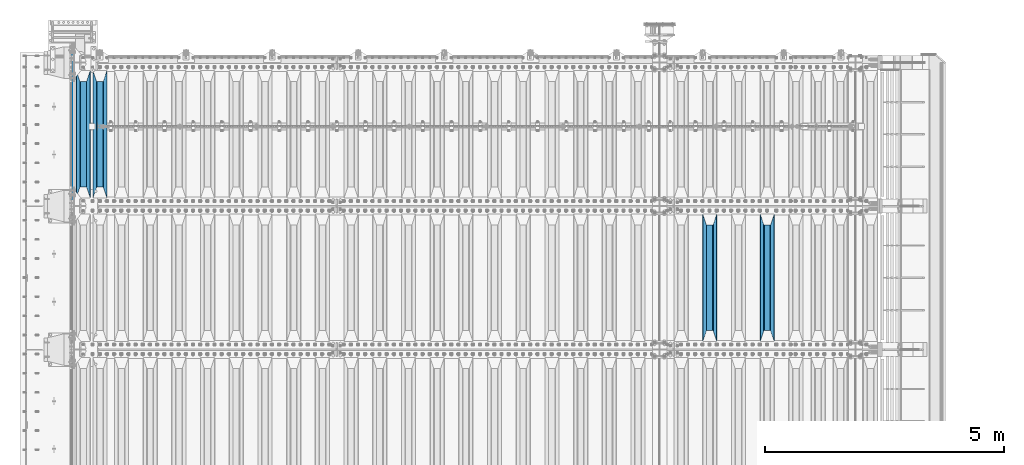
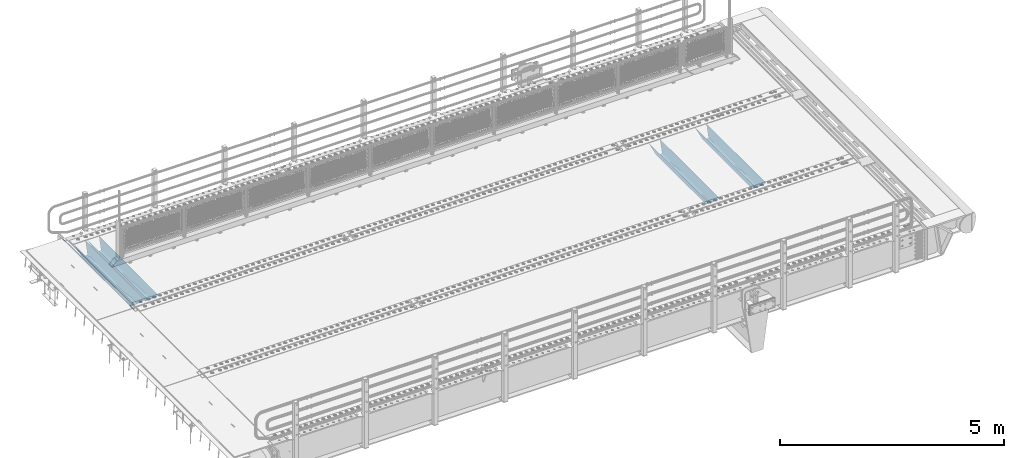
# One storey, part 119 of 247: 5 beams.
"""IFC2X3 building model written with IfcOpenShell, lengths in millimetres."""

from ifc_helpers import new_model, si_unit, frame, origin_with_axes, place, context, subcontext, project, spatial, faceted_brep, material, type_object, element, save


model = new_model("IFC2X3")

# Units and contexts
model_context = context("Model", 3, precision=1e-05, world=origin_with_axes())
body_context = subcontext(model_context, "Body", "Model", "MODEL_VIEW")
ifc_project = project(units=[si_unit("LENGTHUNIT", "METRE", prefix="MILLI"), si_unit("AREAUNIT", "SQUARE_METRE"), si_unit("VOLUMEUNIT", "CUBIC_METRE"), si_unit("MASSUNIT", "GRAM", prefix="KILO"), si_unit("TIMEUNIT", "SECOND"), si_unit("PLANEANGLEUNIT", "RADIAN"), si_unit("SOLIDANGLEUNIT", "STERADIAN"), si_unit("THERMODYNAMICTEMPERATUREUNIT", "DEGREE_CELSIUS"), si_unit("LUMINOUSINTENSITYUNIT", "LUMEN")], contexts=[model_context])

# Site, building, storey
site_placement = place(None, origin_with_axes())
site = spatial("IfcSite", under=ifc_project, at=site_placement, CompositionType="ELEMENT")
building_placement = place(site_placement, origin_with_axes())
building = spatial("IfcBuilding", under=site, at=building_placement, Name="Standard", CompositionType="ELEMENT")
storey_placement = place(building_placement, origin_with_axes())
storey = spatial("IfcBuildingStorey", under=building, at=storey_placement, Name="Undefined", CompositionType="ELEMENT", Elevation=0.0)

# Beams
ifc_material = material(Name="STEEL/S355N")
beam_type_1 = type_object("IfcBeamType", Name="D20", PredefinedType="NOTDEFINED")
beam_1_placement = place(storey_placement, frame((-35.0, 6004.99999999998, -25.9999999971316), z_axis=(0.0, 0.0, 1.0), x_axis=(0.0, 1.0, 0.0)))
element("IfcBeam", 1, at=beam_1_placement, inside=storey, type_object=beam_type_1, material=ifc_material, ObjectType="D20", context=body_context, shape_type="Brep", body=[
    faceted_brep([(-5.6843418860808e-14, -9.99999999999989, 3.5527136788005e-15), (0.0, -7.07106781186531, -7.07106781186547), (3144.99999999998, -7.07106781186548, -7.07106781186548), (3144.99999999998, -10.0, 0.0), (-5.6843418860808e-14, 0.0, -10.0), (3144.99999999998, 0.0, -10.0), (0.0, 7.07106781186565, -7.07106781186547), (3144.99999999998, 7.07106781186548, -7.07106781186547), (-5.6843418860808e-14, 10.0000000000001, 3.5527136788005e-15), (3144.99999999998, 10.0, 0.0), (-5.6843418860808e-14, 7.07106781186553, 7.07106781186548), (3144.99999999998, 7.07106781186548, 7.07106781186548), (0.0, 0.0, 10.0), (3144.99999999998, 0.0, 10.0), (-5.6843418860808e-14, -7.07106781186542, 7.07106781186548), (3144.99999999998, -7.07106781186548, 7.07106781186548)], [[[0, 1, 2, 3]], [[1, 4, 5, 2]], [[4, 6, 7, 5]], [[6, 8, 9, 7]], [[8, 10, 11, 9]], [[10, 12, 13, 11]], [[12, 14, 15, 13]], [[14, 0, 3, 15]], [[5, 7, 9, 11, 13, 15, 3, 2]], [[14, 12, 10, 8, 6, 4, 1, 0]]]),
])
beam_type_2 = type_object("IfcBeamType", PredefinedType="NOTDEFINED")
beam_2_placement = place(storey_placement, frame((14500.0, 3175.0, -115.0), z_axis=(0.0, 0.0, 1.0), x_axis=(0.0, 1.0, 0.0)))
element("IfcBeam", 2, at=beam_2_placement, inside=storey, type_object=beam_type_2, material=ifc_material, context=body_context, shape_type="Brep", body=[
    faceted_brep([(0.0, 150.0, 115.0), (0.0, 143.689999999999, 115.0), (2650.00000000297, 143.689999999999, 115.0), (2650.00000000297, 150.0, 115.0), (2650.00000000297, 142.059565218402, 110.0000000031), (2650.00000000297, 148.369565218403, 110.0000000031), (2441.90079219208, -80.1103600731112, -98.0992078077845), (2437.7588105432, -77.5672621345584, -102.241189456673), (2434.06523489746, -74.4080125315522, -105.934765102404), (2430.91086095089, -70.710272125576, -109.089139048974), (2428.37322971128, -66.5649389910068, -111.626770288588), (2426.51472138054, -62.0739139532889, -113.485278619323), (2425.38102192091, -57.3475956567672, -114.618978078955), (2424.99999999987, -52.5021667386536, -115.0), (2424.99999999987, 52.5021667386536, -115.0), (2425.38102192091, 57.3475956567672, -114.618978078955), (2426.51472138054, 62.0739139532889, -113.485278619323), (2428.37322971128, 66.5649389910068, -111.626770288588), (2430.91086095089, 70.710272125576, -109.089139048974), (2434.06523489746, 74.4080125315522, -105.934765102404), (2437.7588105432, 77.5672621345584, -102.241189456673), (2441.90079219208, 80.1103600731112, -98.0992078077846), (2446.38936140511, 81.9747917625791, -93.6106385947584), (2448.24948500409, 76.2713538057251, -91.7505149957729), (2444.62967112262, 74.76777986261, -95.3703288772456), (2441.28936334126, 72.7168944282894, -98.710636658607), (2438.31067330438, 70.1691124903846, -101.689326695487), (2435.76682334747, 67.1870637758839, -104.233176652398), (2433.72034654133, 63.8440531834895, -106.279653458539), (2432.22154950041, 60.222258798236, -107.778450499454), (2431.30727574265, 56.4107117849089, -108.692724257221), (2430.99999999987, 52.5031078186876, -109.0), (2430.99999999987, -52.5031078186876, -109.0), (2431.30727574265, -56.4107117849089, -108.692724257221), (2432.22154950041, -60.222258798236, -107.778450499454), (2433.72034654133, -63.8440531834895, -106.279653458539), (2435.76682334747, -67.1870637758839, -104.233176652398), (2438.31067330438, -70.1691124903846, -101.689326695487), (2441.28936334126, -72.7168944282894, -98.7106366586071), (2444.62967112262, -74.76777986261, -95.3703288772457), (2448.24948500409, -76.2713538057251, -91.7505149957729), (2650.00000000297, -142.059565218402, 110.0000000031), (2650.00000000297, -148.369565218403, 110.0000000031), (2446.38936140511, -81.9747917625791, -93.6106385947584), (2650.00000000297, -143.689999999999, 115.0), (2650.00000000297, -150.0, 115.0), (0.0, -143.689999999999, 115.0), (0.0, -150.0, 115.0), (0.0, -148.369565218261, 110.000000002663), (203.610638597422, -81.9747917625791, -93.6106385947584), (208.099207810448, -80.1103600731112, -98.0992078077845), (212.241189459336, -77.5672621345584, -102.241189456673), (215.934765105068, -74.4080125315522, -105.934765102404), (219.089139051637, -70.710272125576, -109.089139048974), (221.626770291251, -66.5649389910068, -111.626770288588), (223.485278621985, -62.0739139532889, -113.485278619323), (224.618978081617, -57.3475956567672, -114.618978078955), (225.000000002663, -52.5021667386536, -115.0), (225.000000002663, 52.5021667386536, -115.0), (224.618978081617, 57.3475956567672, -114.618978078955), (223.485278621985, 62.0739139532889, -113.485278619323), (221.626770291251, 66.5649389910068, -111.626770288588), (219.089139051637, 70.710272125576, -109.089139048974), (215.934765105068, 74.4080125315522, -105.934765102404), (212.241189459336, 77.5672621345584, -102.241189456673), (208.099207810448, 80.1103600731112, -98.0992078077846), (203.610638597422, 81.9747917625791, -93.6106385947584), (0.0, 148.369565218261, 110.000000002663), (0.0, 142.05956521826, 110.000000002663), (201.750514998436, 76.2713538057251, -91.7505149957729), (205.370328879908, 74.76777986261, -95.3703288772456), (208.710636661271, 72.7168944282894, -98.710636658607), (211.68932669815, 70.1691124903846, -101.689326695487), (214.233176655061, 67.1870637758839, -104.233176652398), (216.279653461202, 63.8440531834895, -106.279653458539), (217.778450502117, 60.222258798236, -107.778450499454), (218.692724259885, 56.4107117849089, -108.692724257221), (219.000000002663, 52.5031078186876, -109.0), (219.000000002663, -52.5031078186876, -109.0), (218.692724259885, -56.4107117849089, -108.692724257221), (217.778450502117, -60.222258798236, -107.778450499454), (216.279653461202, -63.8440531834895, -106.279653458539), (214.233176655061, -67.1870637758839, -104.233176652398), (211.68932669815, -70.1691124903846, -101.689326695487), (208.710636661271, -72.7168944282894, -98.7106366586071), (205.370328879908, -74.76777986261, -95.3703288772457), (201.750514998436, -76.2713538057251, -91.7505149957729), (0.0, -142.05956521826, 110.000000002663)], [[[0, 1, 2, 3]], [[3, 2, 4, 5]], [[6, 7, 8, 9, 10, 11, 12, 13, 14, 15, 16, 17, 18, 19, 20, 21, 22, 5, 4, 23, 24, 25, 26, 27, 28, 29, 30, 31, 32, 33, 34, 35, 36, 37, 38, 39, 40, 41, 42, 43]], [[44, 45, 42, 41]], [[46, 47, 45, 44]], [[43, 42, 45, 47, 48, 49]], [[6, 43, 49, 50]], [[7, 6, 50, 51]], [[8, 7, 51, 52]], [[9, 8, 52, 53]], [[10, 9, 53, 54]], [[11, 10, 54, 55]], [[12, 11, 55, 56]], [[13, 12, 56, 57]], [[14, 13, 57, 58]], [[15, 14, 58, 59]], [[16, 15, 59, 60]], [[17, 16, 60, 61]], [[18, 17, 61, 62]], [[19, 18, 62, 63]], [[20, 19, 63, 64]], [[21, 20, 64, 65]], [[22, 21, 65, 66]], [[0, 3, 5, 22, 66, 67]], [[1, 0, 67, 68]], [[23, 4, 2, 1, 68, 69]], [[24, 23, 69, 70]], [[25, 24, 70, 71]], [[26, 25, 71, 72]], [[27, 26, 72, 73]], [[28, 27, 73, 74]], [[29, 28, 74, 75]], [[30, 29, 75, 76]], [[31, 30, 76, 77]], [[32, 31, 77, 78]], [[33, 32, 78, 79]], [[34, 33, 79, 80]], [[35, 34, 80, 81]], [[36, 35, 81, 82]], [[37, 36, 82, 83]], [[38, 37, 83, 84]], [[39, 38, 84, 85]], [[40, 39, 85, 86]], [[46, 44, 41, 40, 86, 87]], [[47, 46, 87, 48]], [[86, 85, 84, 83, 82, 81, 80, 79, 78, 77, 76, 75, 74, 73, 72, 71, 70, 69, 68, 67, 66, 65, 64, 63, 62, 61, 60, 59, 58, 57, 56, 55, 54, 53, 52, 51, 50, 49, 48, 87]]]),
])
beam_3_placement = place(storey_placement, frame((13300.0, 3175.0, -115.0), z_axis=(0.0, 0.0, 1.0), x_axis=(0.0, 1.0, 0.0)))
element("IfcBeam", 3, at=beam_3_placement, inside=storey, type_object=beam_type_2, material=ifc_material, context=body_context, shape_type="Brep", body=[
    faceted_brep([(0.0, 150.0, 115.0), (0.0, 143.689999999999, 115.0), (2650.00000000297, 143.689999999999, 115.0), (2650.00000000297, 150.0, 115.0), (2650.00000000297, 142.059565218402, 110.0000000031), (2650.00000000297, 148.369565218403, 110.0000000031), (2441.90079219208, -80.1103600731112, -98.0992078077845), (2437.7588105432, -77.5672621345584, -102.241189456673), (2434.06523489746, -74.4080125315522, -105.934765102404), (2430.91086095089, -70.710272125576, -109.089139048974), (2428.37322971128, -66.5649389910068, -111.626770288588), (2426.51472138054, -62.0739139532889, -113.485278619323), (2425.38102192091, -57.3475956567672, -114.618978078955), (2424.99999999987, -52.5021667386536, -115.0), (2424.99999999987, 52.5021667386536, -115.0), (2425.38102192091, 57.3475956567672, -114.618978078955), (2426.51472138054, 62.0739139532889, -113.485278619323), (2428.37322971128, 66.5649389910068, -111.626770288588), (2430.91086095089, 70.710272125576, -109.089139048974), (2434.06523489746, 74.4080125315522, -105.934765102404), (2437.7588105432, 77.5672621345584, -102.241189456673), (2441.90079219208, 80.1103600731112, -98.0992078077846), (2446.38936140511, 81.9747917625791, -93.6106385947584), (2448.24948500409, 76.2713538057251, -91.7505149957729), (2444.62967112262, 74.76777986261, -95.3703288772456), (2441.28936334126, 72.7168944282894, -98.710636658607), (2438.31067330438, 70.1691124903846, -101.689326695487), (2435.76682334747, 67.1870637758839, -104.233176652398), (2433.72034654133, 63.8440531834895, -106.279653458539), (2432.22154950041, 60.222258798236, -107.778450499454), (2431.30727574265, 56.4107117849089, -108.692724257221), (2430.99999999987, 52.5031078186876, -109.0), (2430.99999999987, -52.5031078186876, -109.0), (2431.30727574265, -56.4107117849089, -108.692724257221), (2432.22154950041, -60.222258798236, -107.778450499454), (2433.72034654133, -63.8440531834895, -106.279653458539), (2435.76682334747, -67.1870637758839, -104.233176652398), (2438.31067330438, -70.1691124903846, -101.689326695487), (2441.28936334126, -72.7168944282894, -98.7106366586071), (2444.62967112262, -74.76777986261, -95.3703288772457), (2448.24948500409, -76.2713538057251, -91.7505149957729), (2650.00000000297, -142.059565218402, 110.0000000031), (2650.00000000297, -148.369565218403, 110.0000000031), (2446.38936140511, -81.9747917625791, -93.6106385947584), (2650.00000000297, -143.689999999999, 115.0), (2650.00000000297, -150.0, 115.0), (0.0, -143.689999999999, 115.0), (0.0, -150.0, 115.0), (0.0, -148.369565218261, 110.000000002663), (203.610638597422, -81.9747917625791, -93.6106385947584), (208.099207810448, -80.1103600731112, -98.0992078077845), (212.241189459336, -77.5672621345584, -102.241189456673), (215.934765105068, -74.4080125315522, -105.934765102404), (219.089139051637, -70.710272125576, -109.089139048974), (221.626770291251, -66.5649389910068, -111.626770288588), (223.485278621985, -62.0739139532889, -113.485278619323), (224.618978081617, -57.3475956567672, -114.618978078955), (225.000000002663, -52.5021667386536, -115.0), (225.000000002663, 52.5021667386536, -115.0), (224.618978081617, 57.3475956567672, -114.618978078955), (223.485278621985, 62.0739139532889, -113.485278619323), (221.626770291251, 66.5649389910068, -111.626770288588), (219.089139051637, 70.710272125576, -109.089139048974), (215.934765105068, 74.4080125315522, -105.934765102404), (212.241189459336, 77.5672621345584, -102.241189456673), (208.099207810448, 80.1103600731112, -98.0992078077846), (203.610638597422, 81.9747917625791, -93.6106385947584), (0.0, 148.369565218261, 110.000000002663), (0.0, 142.05956521826, 110.000000002663), (201.750514998436, 76.2713538057251, -91.7505149957729), (205.370328879908, 74.76777986261, -95.3703288772456), (208.710636661271, 72.7168944282894, -98.710636658607), (211.68932669815, 70.1691124903846, -101.689326695487), (214.233176655061, 67.1870637758839, -104.233176652398), (216.279653461202, 63.8440531834895, -106.279653458539), (217.778450502117, 60.222258798236, -107.778450499454), (218.692724259885, 56.4107117849089, -108.692724257221), (219.000000002663, 52.5031078186876, -109.0), (219.000000002663, -52.5031078186876, -109.0), (218.692724259885, -56.4107117849089, -108.692724257221), (217.778450502117, -60.222258798236, -107.778450499454), (216.279653461202, -63.8440531834895, -106.279653458539), (214.233176655061, -67.1870637758839, -104.233176652398), (211.68932669815, -70.1691124903846, -101.689326695487), (208.710636661271, -72.7168944282894, -98.7106366586071), (205.370328879908, -74.76777986261, -95.3703288772457), (201.750514998436, -76.2713538057251, -91.7505149957729), (0.0, -142.05956521826, 110.000000002663)], [[[0, 1, 2, 3]], [[3, 2, 4, 5]], [[6, 7, 8, 9, 10, 11, 12, 13, 14, 15, 16, 17, 18, 19, 20, 21, 22, 5, 4, 23, 24, 25, 26, 27, 28, 29, 30, 31, 32, 33, 34, 35, 36, 37, 38, 39, 40, 41, 42, 43]], [[44, 45, 42, 41]], [[46, 47, 45, 44]], [[43, 42, 45, 47, 48, 49]], [[6, 43, 49, 50]], [[7, 6, 50, 51]], [[8, 7, 51, 52]], [[9, 8, 52, 53]], [[10, 9, 53, 54]], [[11, 10, 54, 55]], [[12, 11, 55, 56]], [[13, 12, 56, 57]], [[14, 13, 57, 58]], [[15, 14, 58, 59]], [[16, 15, 59, 60]], [[17, 16, 60, 61]], [[18, 17, 61, 62]], [[19, 18, 62, 63]], [[20, 19, 63, 64]], [[21, 20, 64, 65]], [[22, 21, 65, 66]], [[0, 3, 5, 22, 66, 67]], [[1, 0, 67, 68]], [[23, 4, 2, 1, 68, 69]], [[24, 23, 69, 70]], [[25, 24, 70, 71]], [[26, 25, 71, 72]], [[27, 26, 72, 73]], [[28, 27, 73, 74]], [[29, 28, 74, 75]], [[30, 29, 75, 76]], [[31, 30, 76, 77]], [[32, 31, 77, 78]], [[33, 32, 78, 79]], [[34, 33, 79, 80]], [[35, 34, 80, 81]], [[36, 35, 81, 82]], [[37, 36, 82, 83]], [[38, 37, 83, 84]], [[39, 38, 84, 85]], [[40, 39, 85, 86]], [[46, 44, 41, 40, 86, 87]], [[47, 46, 87, 48]], [[86, 85, 84, 83, 82, 81, 80, 79, 78, 77, 76, 75, 74, 73, 72, 71, 70, 69, 68, 67, 66, 65, 64, 63, 62, 61, 60, 59, 58, 57, 56, 55, 54, 53, 52, 51, 50, 49, 48, 87]]]),
])
beam_4_placement = place(storey_placement, frame((550.0, 6175.0, -115.0), z_axis=(0.0, 0.0, 1.0), x_axis=(0.0, 1.0, 0.0)))
element("IfcBeam", 4, at=beam_4_placement, inside=storey, type_object=beam_type_2, material=ifc_material, context=body_context, shape_type="Brep", body=[
    faceted_brep([(0.0, 150.0, 115.0), (0.0, 143.689999999999, 115.0), (2650.00000000297, 143.689999999999, 115.0), (2650.00000000297, 150.0, 115.0), (2650.00000000297, 142.059565218402, 110.0000000031), (2650.00000000297, 148.369565218403, 110.0000000031), (2441.90079219208, -80.1103600731112, -98.0992078077845), (2437.7588105432, -77.5672621345584, -102.241189456673), (2434.06523489746, -74.4080125315522, -105.934765102404), (2430.91086095089, -70.710272125576, -109.089139048974), (2428.37322971128, -66.5649389910068, -111.626770288588), (2426.51472138054, -62.0739139532889, -113.485278619323), (2425.38102192091, -57.3475956567672, -114.618978078955), (2424.99999999987, -52.5021667386536, -115.0), (2424.99999999987, 52.5021667386536, -115.0), (2425.38102192091, 57.3475956567672, -114.618978078955), (2426.51472138054, 62.0739139532889, -113.485278619323), (2428.37322971128, 66.5649389910068, -111.626770288588), (2430.91086095089, 70.710272125576, -109.089139048974), (2434.06523489746, 74.4080125315522, -105.934765102404), (2437.7588105432, 77.5672621345584, -102.241189456673), (2441.90079219208, 80.1103600731112, -98.0992078077846), (2446.38936140511, 81.9747917625791, -93.6106385947584), (2448.24948500409, 76.2713538057251, -91.7505149957729), (2444.62967112262, 74.76777986261, -95.3703288772456), (2441.28936334126, 72.7168944282894, -98.710636658607), (2438.31067330438, 70.1691124903846, -101.689326695487), (2435.76682334747, 67.1870637758839, -104.233176652398), (2433.72034654133, 63.8440531834895, -106.279653458539), (2432.22154950041, 60.222258798236, -107.778450499454), (2431.30727574265, 56.4107117849089, -108.692724257221), (2430.99999999987, 52.5031078186876, -109.0), (2430.99999999987, -52.5031078186876, -109.0), (2431.30727574265, -56.4107117849089, -108.692724257221), (2432.22154950041, -60.222258798236, -107.778450499454), (2433.72034654133, -63.8440531834895, -106.279653458539), (2435.76682334747, -67.1870637758839, -104.233176652398), (2438.31067330438, -70.1691124903846, -101.689326695487), (2441.28936334126, -72.7168944282894, -98.7106366586071), (2444.62967112262, -74.76777986261, -95.3703288772457), (2448.24948500409, -76.2713538057251, -91.7505149957729), (2650.00000000297, -142.059565218402, 110.0000000031), (2650.00000000297, -148.369565218403, 110.0000000031), (2446.38936140511, -81.9747917625791, -93.6106385947584), (2650.00000000297, -143.689999999999, 115.0), (2650.00000000297, -150.0, 115.0), (0.0, -143.689999999999, 115.0), (0.0, -150.0, 115.0), (0.0, -148.369565218261, 110.000000002663), (203.610638597422, -81.9747917625791, -93.6106385947584), (208.099207810448, -80.1103600731112, -98.0992078077845), (212.241189459336, -77.5672621345584, -102.241189456673), (215.934765105068, -74.4080125315522, -105.934765102404), (219.089139051637, -70.710272125576, -109.089139048974), (221.626770291251, -66.5649389910068, -111.626770288588), (223.485278621985, -62.0739139532889, -113.485278619323), (224.618978081617, -57.3475956567672, -114.618978078955), (225.000000002663, -52.5021667386536, -115.0), (225.000000002663, 52.5021667386536, -115.0), (224.618978081617, 57.3475956567672, -114.618978078955), (223.485278621985, 62.0739139532889, -113.485278619323), (221.626770291251, 66.5649389910068, -111.626770288588), (219.089139051637, 70.710272125576, -109.089139048974), (215.934765105068, 74.4080125315522, -105.934765102404), (212.241189459336, 77.5672621345584, -102.241189456673), (208.099207810448, 80.1103600731112, -98.0992078077846), (203.610638597422, 81.9747917625791, -93.6106385947584), (0.0, 148.369565218261, 110.000000002663), (0.0, 142.05956521826, 110.000000002663), (201.750514998436, 76.2713538057251, -91.7505149957729), (205.370328879908, 74.76777986261, -95.3703288772456), (208.710636661271, 72.7168944282894, -98.710636658607), (211.68932669815, 70.1691124903846, -101.689326695487), (214.233176655061, 67.1870637758839, -104.233176652398), (216.279653461202, 63.8440531834895, -106.279653458539), (217.778450502117, 60.222258798236, -107.778450499454), (218.692724259885, 56.4107117849089, -108.692724257221), (219.000000002663, 52.5031078186876, -109.0), (219.000000002663, -52.5031078186876, -109.0), (218.692724259885, -56.4107117849089, -108.692724257221), (217.778450502117, -60.222258798236, -107.778450499454), (216.279653461202, -63.8440531834895, -106.279653458539), (214.233176655061, -67.1870637758839, -104.233176652398), (211.68932669815, -70.1691124903846, -101.689326695487), (208.710636661271, -72.7168944282894, -98.7106366586071), (205.370328879908, -74.76777986261, -95.3703288772457), (201.750514998436, -76.2713538057251, -91.7505149957729), (0.0, -142.05956521826, 110.000000002663)], [[[0, 1, 2, 3]], [[3, 2, 4, 5]], [[6, 7, 8, 9, 10, 11, 12, 13, 14, 15, 16, 17, 18, 19, 20, 21, 22, 5, 4, 23, 24, 25, 26, 27, 28, 29, 30, 31, 32, 33, 34, 35, 36, 37, 38, 39, 40, 41, 42, 43]], [[44, 45, 42, 41]], [[46, 47, 45, 44]], [[43, 42, 45, 47, 48, 49]], [[6, 43, 49, 50]], [[7, 6, 50, 51]], [[8, 7, 51, 52]], [[9, 8, 52, 53]], [[10, 9, 53, 54]], [[11, 10, 54, 55]], [[12, 11, 55, 56]], [[13, 12, 56, 57]], [[14, 13, 57, 58]], [[15, 14, 58, 59]], [[16, 15, 59, 60]], [[17, 16, 60, 61]], [[18, 17, 61, 62]], [[19, 18, 62, 63]], [[20, 19, 63, 64]], [[21, 20, 64, 65]], [[22, 21, 65, 66]], [[0, 3, 5, 22, 66, 67]], [[1, 0, 67, 68]], [[23, 4, 2, 1, 68, 69]], [[24, 23, 69, 70]], [[25, 24, 70, 71]], [[26, 25, 71, 72]], [[27, 26, 72, 73]], [[28, 27, 73, 74]], [[29, 28, 74, 75]], [[30, 29, 75, 76]], [[31, 30, 76, 77]], [[32, 31, 77, 78]], [[33, 32, 78, 79]], [[34, 33, 79, 80]], [[35, 34, 80, 81]], [[36, 35, 81, 82]], [[37, 36, 82, 83]], [[38, 37, 83, 84]], [[39, 38, 84, 85]], [[40, 39, 85, 86]], [[46, 44, 41, 40, 86, 87]], [[47, 46, 87, 48]], [[86, 85, 84, 83, 82, 81, 80, 79, 78, 77, 76, 75, 74, 73, 72, 71, 70, 69, 68, 67, 66, 65, 64, 63, 62, 61, 60, 59, 58, 57, 56, 55, 54, 53, 52, 51, 50, 49, 48, 87]]]),
])
beam_5_placement = place(storey_placement, frame((200.0, 6175.0, -115.0), z_axis=(0.0, 0.0, 1.0), x_axis=(0.0, 1.0, 0.0)))
element("IfcBeam", 5, at=beam_5_placement, inside=storey, type_object=beam_type_2, material=ifc_material, context=body_context, shape_type="Brep", body=[
    faceted_brep([(0.0, 150.0, 115.0), (0.0, 143.689999999999, 115.0), (2650.00000000297, 143.689999999999, 115.0), (2650.00000000297, 150.0, 115.0), (2650.00000000297, 142.059565218402, 110.0000000031), (2650.00000000297, 148.369565218403, 110.0000000031), (2441.90079219208, -80.1103600731112, -98.0992078077845), (2437.7588105432, -77.5672621345584, -102.241189456673), (2434.06523489746, -74.4080125315522, -105.934765102404), (2430.91086095089, -70.710272125576, -109.089139048974), (2428.37322971128, -66.5649389910068, -111.626770288588), (2426.51472138054, -62.0739139532889, -113.485278619323), (2425.38102192091, -57.3475956567672, -114.618978078955), (2424.99999999987, -52.5021667386536, -115.0), (2424.99999999987, 52.5021667386536, -115.0), (2425.38102192091, 57.3475956567672, -114.618978078955), (2426.51472138054, 62.0739139532889, -113.485278619323), (2428.37322971128, 66.5649389910068, -111.626770288588), (2430.91086095089, 70.710272125576, -109.089139048974), (2434.06523489746, 74.4080125315522, -105.934765102404), (2437.7588105432, 77.5672621345584, -102.241189456673), (2441.90079219208, 80.1103600731112, -98.0992078077846), (2446.38936140511, 81.9747917625791, -93.6106385947584), (2448.24948500409, 76.2713538057251, -91.7505149957729), (2444.62967112262, 74.76777986261, -95.3703288772456), (2441.28936334126, 72.7168944282894, -98.710636658607), (2438.31067330438, 70.1691124903846, -101.689326695487), (2435.76682334747, 67.1870637758839, -104.233176652398), (2433.72034654133, 63.8440531834895, -106.279653458539), (2432.22154950041, 60.222258798236, -107.778450499454), (2431.30727574265, 56.4107117849089, -108.692724257221), (2430.99999999987, 52.5031078186876, -109.0), (2430.99999999987, -52.5031078186876, -109.0), (2431.30727574265, -56.4107117849089, -108.692724257221), (2432.22154950041, -60.222258798236, -107.778450499454), (2433.72034654133, -63.8440531834895, -106.279653458539), (2435.76682334747, -67.1870637758839, -104.233176652398), (2438.31067330438, -70.1691124903846, -101.689326695487), (2441.28936334126, -72.7168944282894, -98.7106366586071), (2444.62967112262, -74.76777986261, -95.3703288772457), (2448.24948500409, -76.2713538057251, -91.7505149957729), (2650.00000000297, -142.059565218402, 110.0000000031), (2650.00000000297, -148.369565218403, 110.0000000031), (2446.38936140511, -81.9747917625791, -93.6106385947584), (2650.00000000297, -143.689999999999, 115.0), (2650.00000000297, -150.0, 115.0), (0.0, -143.689999999999, 115.0), (0.0, -150.0, 115.0), (0.0, -148.369565218261, 110.000000002663), (203.610638597422, -81.9747917625791, -93.6106385947584), (208.099207810448, -80.1103600731112, -98.0992078077845), (212.241189459336, -77.5672621345584, -102.241189456673), (215.934765105068, -74.4080125315522, -105.934765102404), (219.089139051637, -70.710272125576, -109.089139048974), (221.626770291251, -66.5649389910068, -111.626770288588), (223.485278621985, -62.0739139532889, -113.485278619323), (224.618978081617, -57.3475956567672, -114.618978078955), (225.000000002663, -52.5021667386536, -115.0), (225.000000002663, 52.5021667386536, -115.0), (224.618978081617, 57.3475956567672, -114.618978078955), (223.485278621985, 62.0739139532889, -113.485278619323), (221.626770291251, 66.5649389910068, -111.626770288588), (219.089139051637, 70.710272125576, -109.089139048974), (215.934765105068, 74.4080125315522, -105.934765102404), (212.241189459336, 77.5672621345584, -102.241189456673), (208.099207810448, 80.1103600731112, -98.0992078077846), (203.610638597422, 81.9747917625791, -93.6106385947584), (0.0, 148.369565218261, 110.000000002663), (0.0, 142.05956521826, 110.000000002663), (201.750514998436, 76.2713538057251, -91.7505149957729), (205.370328879908, 74.76777986261, -95.3703288772456), (208.710636661271, 72.7168944282894, -98.710636658607), (211.68932669815, 70.1691124903846, -101.689326695487), (214.233176655061, 67.1870637758839, -104.233176652398), (216.279653461202, 63.8440531834895, -106.279653458539), (217.778450502117, 60.222258798236, -107.778450499454), (218.692724259885, 56.4107117849089, -108.692724257221), (219.000000002663, 52.5031078186876, -109.0), (219.000000002663, -52.5031078186876, -109.0), (218.692724259885, -56.4107117849089, -108.692724257221), (217.778450502117, -60.222258798236, -107.778450499454), (216.279653461202, -63.8440531834895, -106.279653458539), (214.233176655061, -67.1870637758839, -104.233176652398), (211.68932669815, -70.1691124903846, -101.689326695487), (208.710636661271, -72.7168944282894, -98.7106366586071), (205.370328879908, -74.76777986261, -95.3703288772457), (201.750514998436, -76.2713538057251, -91.7505149957729), (0.0, -142.05956521826, 110.000000002663)], [[[0, 1, 2, 3]], [[3, 2, 4, 5]], [[6, 7, 8, 9, 10, 11, 12, 13, 14, 15, 16, 17, 18, 19, 20, 21, 22, 5, 4, 23, 24, 25, 26, 27, 28, 29, 30, 31, 32, 33, 34, 35, 36, 37, 38, 39, 40, 41, 42, 43]], [[44, 45, 42, 41]], [[46, 47, 45, 44]], [[43, 42, 45, 47, 48, 49]], [[6, 43, 49, 50]], [[7, 6, 50, 51]], [[8, 7, 51, 52]], [[9, 8, 52, 53]], [[10, 9, 53, 54]], [[11, 10, 54, 55]], [[12, 11, 55, 56]], [[13, 12, 56, 57]], [[14, 13, 57, 58]], [[15, 14, 58, 59]], [[16, 15, 59, 60]], [[17, 16, 60, 61]], [[18, 17, 61, 62]], [[19, 18, 62, 63]], [[20, 19, 63, 64]], [[21, 20, 64, 65]], [[22, 21, 65, 66]], [[0, 3, 5, 22, 66, 67]], [[1, 0, 67, 68]], [[23, 4, 2, 1, 68, 69]], [[24, 23, 69, 70]], [[25, 24, 70, 71]], [[26, 25, 71, 72]], [[27, 26, 72, 73]], [[28, 27, 73, 74]], [[29, 28, 74, 75]], [[30, 29, 75, 76]], [[31, 30, 76, 77]], [[32, 31, 77, 78]], [[33, 32, 78, 79]], [[34, 33, 79, 80]], [[35, 34, 80, 81]], [[36, 35, 81, 82]], [[37, 36, 82, 83]], [[38, 37, 83, 84]], [[39, 38, 84, 85]], [[40, 39, 85, 86]], [[46, 44, 41, 40, 86, 87]], [[47, 46, 87, 48]], [[86, 85, 84, 83, 82, 81, 80, 79, 78, 77, 76, 75, 74, 73, 72, 71, 70, 69, 68, 67, 66, 65, 64, 63, 62, 61, 60, 59, 58, 57, 56, 55, 54, 53, 52, 51, 50, 49, 48, 87]]]),
])

save(model, "model.ifc")
